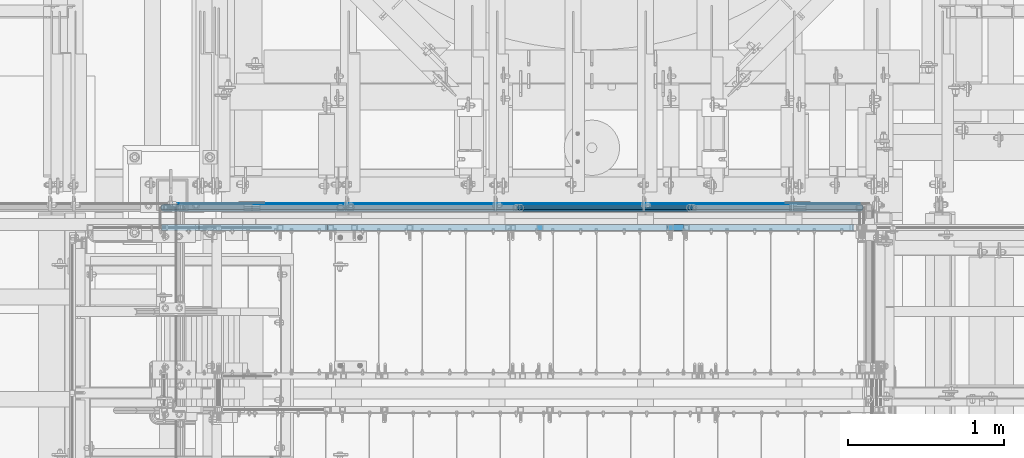
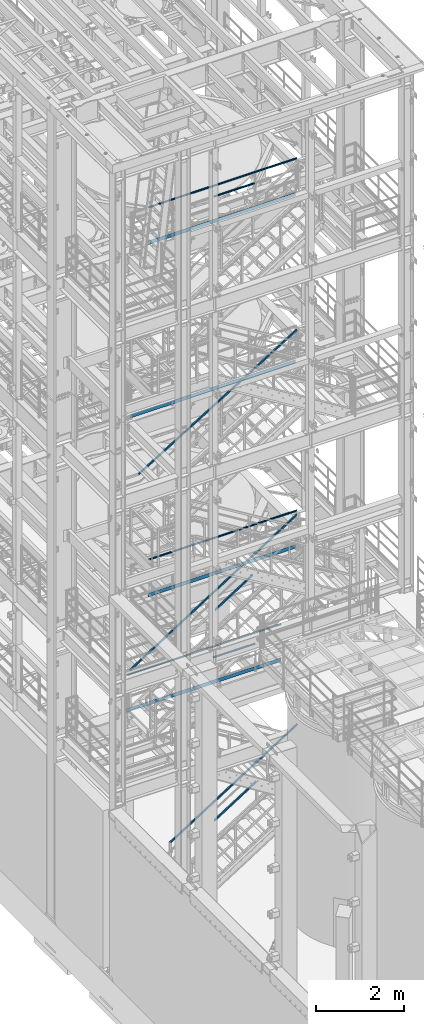
# One storey, part 978 of 1876: 9 beams, 5 members, 7 elements without a shape of their own.
"""IFC2X3 building model written with IfcOpenShell, lengths in millimetres."""

from ifc_helpers import new_model, si_unit, frame, origin_with_axes, place, context, subcontext, project, spatial, faceted_brep, material, type_object, element, aggregate, save


model = new_model("IFC2X3")

# Units and contexts
model_context = context("Model", 3, precision=1e-05, world=origin_with_axes())
body_context = subcontext(model_context, "Body", "Model", "MODEL_VIEW")
ifc_project = project(units=[si_unit("LENGTHUNIT", "METRE", prefix="MILLI"), si_unit("AREAUNIT", "SQUARE_METRE"), si_unit("VOLUMEUNIT", "CUBIC_METRE"), si_unit("MASSUNIT", "GRAM", prefix="KILO"), si_unit("TIMEUNIT", "SECOND"), si_unit("PLANEANGLEUNIT", "RADIAN"), si_unit("SOLIDANGLEUNIT", "STERADIAN"), si_unit("THERMODYNAMICTEMPERATUREUNIT", "DEGREE_CELSIUS"), si_unit("LUMINOUSINTENSITYUNIT", "LUMEN")], contexts=[model_context])

# Site, building, storey
site_placement = place(None, origin_with_axes())
site = spatial("IfcSite", under=ifc_project, at=site_placement, CompositionType="ELEMENT")
building_placement = place(site_placement, origin_with_axes())
building = spatial("IfcBuilding", under=site, at=building_placement, Name="Undefined", CompositionType="ELEMENT")
storey_placement = place(building_placement, origin_with_axes())
storey = spatial("IfcBuildingStorey", under=building, at=storey_placement, Name="Undefined", CompositionType="ELEMENT", Elevation=0.0)

# Assembly, beam
assembly_1_placement = place(storey_placement, origin_with_axes())
assembly_1 = element("IfcElementAssembly", 1, at=assembly_1_placement, inside=storey, Name="RAIL", AssemblyPlace="NOTDEFINED", PredefinedType="RIGID_FRAME")
ifc_material_1 = material()
beam_type_1 = type_object("IfcBeamType", Name="PIPE1-1/2SCH40", PredefinedType="NOTDEFINED")
beam_1_placement = place(assembly_1_placement, frame((2238.37499998822, -4654.55000114555, 9229.725), z_axis=(0.0, 0.0, -1.0), x_axis=(1.0, 0.0, 0.0)))
beam_1 = element("IfcBeam", 2, at=beam_1_placement, type_object=beam_type_1, material=ifc_material_1, Name="RAIL", ObjectType="PIPE1-1/2SCH40", context=body_context, shape_type="Brep", body=[
    faceted_brep([(1.58700000000044, -20.4470000000001, 0.0), (1.58700000000044, -17.7076214311801, 10.2235000000001), (3888.67649996469, -17.7076214311801, 10.2235000000001), (3898.89999996469, -20.4470000000001, 0.0), (1.58700000000044, -10.2235000000001, 17.7076214311801), (3881.19237853351, -10.2235000000001, 17.7076214311801), (1.58700000000044, 0.0, 20.4470000000001), (3878.45299996469, 0.0, 20.4470000000001), (1.58700000000044, 10.2235000000001, 17.7076214311801), (3881.19237853351, 10.2235000000001, 17.7076214311801), (1.58700000000044, 17.7076214311801, 10.2235000000001), (3888.67649996469, 17.7076214311801, 10.2235000000001), (1.58700000000044, 20.4470000000001, 0.0), (3898.89999996469, 20.4470000000001, 0.0), (1.58700000000044, 17.7076214311801, -10.2235000000001), (3909.12349996469, 17.7076214311801, -10.2235000000001), (1.58700000000044, 10.2235000000001, -17.7076214311801), (3916.60762139587, 10.2235000000001, -17.7076214311801), (1.58700000000044, 0.0, -20.4470000000001), (3919.34699996469, 0.0, -20.4470000000001), (1.58700000000044, -10.2235000000001, -17.7076214311801), (3916.60762139587, -10.2235000000001, -17.7076214311801), (1.58700000000044, -17.7076214311801, -10.2235000000001), (3909.12349996469, -17.7076214311801, -10.2235000000001), (1.58700000000044, -24.1300000000001, 0.0), (1.58700000000044, -20.8971929933186, -12.0649999999996), (3910.96499996469, -20.8971929933186, -12.0650000000005), (3898.89999996469, -24.1300000000001, 0.0), (1.58700000000044, -12.0649999999996, -20.8971929933186), (3919.79719295801, -12.0649999999996, -20.8971929933177), (1.58700000000044, 0.0, -24.1300000000001), (3923.02999996469, 0.0, -24.1299999999992), (1.58700000000044, 12.0649999999996, -20.8971929933186), (3919.79719295801, 12.0649999999996, -20.8971929933177), (1.58700000000044, 20.8971929933186, -12.0649999999996), (3910.96499996469, 20.8971929933186, -12.0650000000005), (1.58700000000044, 24.1300000000001, 0.0), (3898.89999996469, 24.1300000000001, 0.0), (1.58700000000044, 20.8971929933186, 12.0649999999996), (3886.83499996469, 20.8971929933186, 12.0650000000005), (1.58700000000044, 12.0649999999996, 20.8971929933186), (3878.00280697137, 12.0649999999996, 20.8971929933177), (1.58700000000044, 0.0, 24.1300000000001), (3874.76999996469, 0.0, 24.1299999999992), (1.58700000000044, -12.0649999999996, 20.8971929933186), (3878.00280697137, -12.0649999999996, 20.8971929933177), (1.58700000000044, -20.8971929933186, 12.0649999999996), (3886.83499996469, -20.8971929933186, 12.0650000000005)], [[[0, 1, 2, 3]], [[1, 4, 5, 2]], [[4, 6, 7, 5]], [[6, 8, 9, 7]], [[8, 10, 11, 9]], [[10, 12, 13, 11]], [[12, 14, 15, 13]], [[14, 16, 17, 15]], [[16, 18, 19, 17]], [[18, 20, 21, 19]], [[20, 22, 23, 21]], [[22, 0, 3, 23]], [[24, 25, 26, 27]], [[25, 28, 29, 26]], [[28, 30, 31, 29]], [[30, 32, 33, 31]], [[32, 34, 35, 33]], [[34, 36, 37, 35]], [[36, 38, 39, 37]], [[38, 40, 41, 39]], [[40, 42, 43, 41]], [[42, 44, 45, 43]], [[44, 46, 47, 45]], [[46, 24, 27, 47]], [[29, 31, 33, 35, 37, 39, 41, 43, 45, 47, 27, 26], [5, 7, 9, 11, 13, 15, 17, 19, 21, 23, 3, 2]], [[46, 44, 42, 40, 38, 36, 34, 32, 30, 28, 25, 24], [22, 20, 18, 16, 14, 12, 10, 8, 6, 4, 1, 0]]]),
])

# Assembly, beams
assembly_2_placement = place(storey_placement, origin_with_axes())
assembly_2 = element("IfcElementAssembly", 3, at=assembly_2_placement, inside=storey, Name="RAIL", AssemblyPlace="NOTDEFINED", PredefinedType="RIGID_FRAME")
beam_2_placement = place(assembly_2_placement, frame((3959.22499997644, -4654.55000114554, 18754.725), z_axis=(0.0, 0.0, -1.0), x_axis=(1.0, 0.0, 0.0)))
beam_2 = element("IfcBeam", 4, at=beam_2_placement, type_object=beam_type_1, material=ifc_material_1, Name="RAIL", ObjectType="PIPE1-1/2SCH40", context=body_context, shape_type="Brep", body=[
    faceted_brep([(0.0, 24.1299999999992, 0.0), (12.0650000000064, 20.8971929933177, -12.0649999999987), (12.0650000000064, 20.8971929933177, 12.0649999999987), (12.0650000000064, -20.8971929933177, 12.0649999999987), (12.0650000000064, -20.8971929933177, -12.0649999999987), (0.0, -24.1299999999992, 0.0), (20.8971929933249, -12.0650000000005, 20.8971929933177), (20.8971929933249, -12.0650000000005, 15.8661214311796), (15.2545715621445, -17.7076214311801, 10.2235000000001), (12.5151929933249, -20.4470000000001, 0.0), (15.2545715621445, -17.7076214311801, -10.2235000000001), (20.8971929933249, -12.0650000000005, -15.8661214311796), (20.8971929933249, -12.0650000000005, -20.8971929933177), (24.1300000000063, 0.0, -20.4470000000001), (24.1300000000063, 0.0, -24.130000000001), (21.3906214311868, -10.2235000000001, -17.7076214311819), (21.3906214311868, 10.2235000000001, -17.7076214311819), (20.8971929933249, 12.0650000000005, -15.8661214311796), (20.8971929933249, 12.0650000000005, -20.8971929933177), (15.2545715621445, 17.7076214311801, -10.2235000000001), (12.5151929933249, 20.4470000000001, 0.0), (15.2545715621445, 17.7076214311801, 10.2235000000001), (20.8971929933249, 12.0650000000005, 15.8661214311796), (20.8971929933249, 12.0650000000005, 20.8971929933177), (21.3906214311868, 10.2235000000001, 17.7076214311819), (24.1300000000064, 0.0, 20.4470000000001), (24.1300000000064, 0.0, 24.130000000001), (21.3906214311868, -10.2235000000001, 17.7076214311819), (1089.02499998822, 24.1300000000001, 0.0), (1076.95999998821, 20.8971929933186, -12.0650000000005), (1068.12780699489, 12.0649999999996, -20.8971929933177), (1089.02499998821, -24.1299999999865, 0.0), (1076.95999998821, -20.8971929933186, -12.0650000000005), (1076.95999998821, -20.8971929933186, 12.0650000000005), (1068.12780699489, -12.0649999999996, 20.8971929933177), (1068.12780699489, -12.0649999999996, -20.8971929933177), (1064.89499998821, 0.0, -24.1299999999992), (1067.63437855703, 10.2235000000001, -17.7076214311801), (1064.89499998821, 0.0, -20.4470000000001), (1068.12780699489, 12.0650000000132, -15.8661214311669), (1068.12780699489, -12.064999999986, -15.8661214311942), (1067.63437855703, -10.2235000000001, -17.7076214311801), (1073.77042842609, -17.7076214311801, -10.2235000000001), (1076.50980699491, -20.4470000000001, 0.0), (1073.77042842609, -17.7076214311801, 10.2235000000001), (1068.12780699489, -12.064999999986, 15.8661214311942), (1067.63437855703, -10.2235000000001, 17.7076214311801), (1064.89499998821, 0.0, 20.4470000000001), (1064.89499998821, 0.0, 24.1299999999992), (1068.12780699489, 12.0649999999996, 20.8971929933177), (1076.95999998821, 20.8971929933186, 12.0650000000005), (1068.12780699489, 12.0650000000132, 15.8661214311669), (1073.77042842606, 17.7076214311801, 10.2235000000001), (1076.50980699488, 20.4470000000001, 0.0), (1073.77042842606, 17.7076214311801, -10.2235000000001), (1067.63437855703, 10.2235000000001, 17.7076214311801)], [[[0, 1, 2]], [[3, 4, 5]], [[6, 7, 8, 9, 10, 11, 12, 4, 3]], [[13, 14, 12, 11, 15]], [[16, 17, 18, 14, 13]], [[2, 1, 18, 17, 19, 20, 21, 22, 23]], [[23, 22, 24, 25, 26]], [[26, 25, 27, 7, 6]], [[1, 0, 28, 29]], [[18, 1, 29, 30]], [[31, 32, 33]], [[6, 3, 33, 34]], [[3, 5, 31, 33]], [[5, 4, 32, 31]], [[4, 12, 35, 32]], [[12, 14, 36, 35]], [[14, 18, 30, 36]], [[37, 38, 36, 30, 39]], [[40, 35, 36, 38, 41]], [[33, 32, 35, 40, 42, 43, 44, 45, 34]], [[34, 45, 46, 47, 48]], [[26, 6, 34, 48]], [[2, 23, 49, 50]], [[23, 26, 48, 49]], [[0, 2, 50, 28]], [[28, 50, 29]], [[49, 51, 52, 53, 54, 39, 30, 29, 50]], [[48, 47, 55, 51, 49]], [[25, 24, 55, 47]], [[55, 24, 22, 21, 52, 51]], [[21, 20, 53, 52]], [[20, 19, 54, 53]], [[19, 17, 16, 37, 39, 54]], [[16, 13, 38, 37]], [[13, 15, 41, 38]], [[41, 15, 11, 10, 42, 40]], [[10, 9, 43, 42]], [[9, 8, 44, 43]], [[8, 7, 27, 46, 45, 44]], [[27, 25, 47, 46]]]),
])
beam_3_placement = place(assembly_2_placement, frame((2238.37499998822, -4654.55000114555, 19059.525), z_axis=(0.0, 0.0, -1.0), x_axis=(1.0, 0.0, 0.0)))
beam_3 = element("IfcBeam", 5, at=beam_3_placement, type_object=beam_type_1, material=ifc_material_1, Name="RAIL", ObjectType="PIPE1-1/2SCH40", context=body_context, shape_type="Brep", body=[
    faceted_brep([(1.58700000000044, -20.4470000000001, 0.0), (1.58700000000044, -17.7076214311801, 10.2235000000001), (3888.67649996469, -17.7076214311801, 10.2235000000001), (3898.89999996469, -20.4470000000001, 0.0), (1.58700000000044, -10.2235000000001, 17.7076214311801), (3881.19237853351, -10.2235000000001, 17.7076214311801), (1.58700000000044, 0.0, 20.4470000000001), (3878.45299996469, 0.0, 20.4470000000001), (1.58700000000044, 10.2235000000001, 17.7076214311801), (3881.19237853351, 10.2235000000001, 17.7076214311801), (1.58700000000044, 17.7076214311801, 10.2235000000001), (3888.67649996469, 17.7076214311801, 10.2235000000001), (1.58700000000044, 20.4470000000001, 0.0), (3898.89999996469, 20.4470000000001, 0.0), (1.58700000000044, 17.7076214311801, -10.2235000000001), (3909.12349996469, 17.7076214311801, -10.2235000000001), (1.58700000000044, 10.2235000000001, -17.7076214311801), (3916.60762139587, 10.2235000000001, -17.7076214311801), (1.58700000000044, 0.0, -20.4470000000001), (3919.34699996469, 0.0, -20.4470000000001), (1.58700000000044, -10.2235000000001, -17.7076214311801), (3916.60762139587, -10.2235000000001, -17.7076214311801), (1.58700000000044, -17.7076214311801, -10.2235000000001), (3909.12349996469, -17.7076214311801, -10.2235000000001), (1.58700000000044, -24.1300000000001, 0.0), (1.58700000000044, -20.8971929933186, -12.0649999999996), (3910.96499996469, -20.8971929933186, -12.0650000000005), (3898.89999996469, -24.1300000000001, 0.0), (1.58700000000044, -12.0649999999996, -20.8971929933186), (3919.79719295801, -12.0649999999996, -20.8971929933177), (1.58700000000044, 0.0, -24.1300000000001), (3923.02999996469, 0.0, -24.1299999999992), (1.58700000000044, 12.0649999999996, -20.8971929933186), (3919.79719295801, 12.0649999999996, -20.8971929933177), (1.58700000000044, 20.8971929933186, -12.0649999999996), (3910.96499996469, 20.8971929933186, -12.0650000000005), (1.58700000000044, 24.1300000000001, 0.0), (3898.89999996469, 24.1300000000001, 0.0), (1.58700000000044, 20.8971929933186, 12.0649999999996), (3886.83499996469, 20.8971929933186, 12.0650000000005), (1.58700000000044, 12.0649999999996, 20.8971929933186), (3878.00280697137, 12.0649999999996, 20.8971929933177), (1.58700000000044, 0.0, 24.1300000000001), (3874.76999996469, 0.0, 24.1299999999992), (1.58700000000044, -12.0649999999996, 20.8971929933186), (3878.00280697137, -12.0649999999996, 20.8971929933177), (1.58700000000044, -20.8971929933186, 12.0649999999996), (3886.83499996469, -20.8971929933186, 12.0650000000005)], [[[0, 1, 2, 3]], [[1, 4, 5, 2]], [[4, 6, 7, 5]], [[6, 8, 9, 7]], [[8, 10, 11, 9]], [[10, 12, 13, 11]], [[12, 14, 15, 13]], [[14, 16, 17, 15]], [[16, 18, 19, 17]], [[18, 20, 21, 19]], [[20, 22, 23, 21]], [[22, 0, 3, 23]], [[24, 25, 26, 27]], [[25, 28, 29, 26]], [[28, 30, 31, 29]], [[30, 32, 33, 31]], [[32, 34, 35, 33]], [[34, 36, 37, 35]], [[36, 38, 39, 37]], [[38, 40, 41, 39]], [[40, 42, 43, 41]], [[42, 44, 45, 43]], [[44, 46, 47, 45]], [[46, 24, 27, 47]], [[29, 31, 33, 35, 37, 39, 41, 43, 45, 47, 27, 26], [5, 7, 9, 11, 13, 15, 17, 19, 21, 23, 3, 2]], [[46, 44, 42, 40, 38, 36, 34, 32, 30, 28, 25, 24], [22, 20, 18, 16, 14, 12, 10, 8, 6, 4, 1, 0]]]),
])

assembly_3_placement = place(storey_placement, origin_with_axes())
assembly_3 = element("IfcElementAssembly", 6, at=assembly_3_placement, inside=storey, Name="RAIL", AssemblyPlace="NOTDEFINED", PredefinedType="RIGID_FRAME")
beam_4_placement = place(assembly_3_placement, frame((5067.30000007784, -4654.55000114548, 5902.325), z_axis=(0.0, 0.0, -1.0), x_axis=(-1.0, 0.0, 0.0)))
beam_4 = element("IfcBeam", 7, at=beam_4_placement, type_object=beam_type_1, material=ifc_material_1, Name="RAIL", ObjectType="PIPE1-1/2SCH40", context=body_context, shape_type="Brep", body=[
    faceted_brep([(0.0, 24.1299999999992, 0.0), (12.0650000000064, 20.8971929933177, -12.0649999999987), (12.0650000000064, 20.8971929933177, 12.0649999999987), (12.0650000000064, -20.8971929933177, 12.0649999999987), (12.0650000000064, -20.8971929933177, -12.0649999999987), (0.0, -24.1299999999992, 0.0), (20.8971929933249, -12.0650000000005, 20.8971929933177), (20.8971929933249, -12.0650000000005, 15.8661214311796), (15.2545715621445, -17.7076214311801, 10.2235000000001), (12.5151929933249, -20.4470000000001, 0.0), (15.2545715621445, -17.7076214311801, -10.2235000000001), (20.8971929933249, -12.0650000000005, -15.8661214311796), (20.8971929933249, -12.0650000000005, -20.8971929933177), (24.1300000000063, 0.0, -20.4470000000001), (24.1300000000063, 0.0, -24.130000000001), (21.3906214311868, -10.2235000000001, -17.7076214311819), (21.3906214311868, 10.2235000000001, -17.7076214311819), (20.8971929933249, 12.0650000000005, -15.8661214311796), (20.8971929933249, 12.0650000000005, -20.8971929933177), (15.2545715621445, 17.7076214311801, -10.2235000000001), (12.5151929933249, 20.4470000000001, 0.0), (15.2545715621445, 17.7076214311801, 10.2235000000001), (20.8971929933249, 12.0650000000005, 15.8661214311796), (20.8971929933249, 12.0650000000005, 20.8971929933177), (21.3906214311868, 10.2235000000001, 17.7076214311819), (24.1300000000064, 0.0, 20.4470000000001), (24.1300000000064, 0.0, 24.130000000001), (21.3906214311868, -10.2235000000001, 17.7076214311819), (1130.29999992215, 24.1300000000001, 0.0), (1118.23499992216, 20.8971929933186, -12.0649999999996), (1109.40280692884, 12.0649999999996, -20.8971929933186), (1130.29999992216, -24.1300000000274, 0.0), (1118.23499992216, -20.8971929933186, -12.0649999999996), (1118.23499992216, -20.8971929933186, 12.0649999999996), (1109.40280692884, -12.0649999999996, 20.8971929933186), (1109.40280692884, -12.0649999999996, -20.8971929933186), (1106.16999992216, 0.0, -24.1300000000001), (1108.90937849099, 10.2235000000001, -17.7076214311801), (1106.16999992216, 0.0, -20.4470000000001), (1109.40280692884, 12.0649999999723, -15.8661214312078), (1109.40280692884, -12.0650000000269, -15.8661214311533), (1108.90937849097, -10.2235000000001, -17.7076214311801), (1115.04542835999, -17.7076214311801, -10.2235000000001), (1117.78480692881, -20.4470000000001, 0.0), (1115.04542835999, -17.7076214311801, 10.2235000000001), (1109.40280692884, -12.0650000000269, 15.8661214311533), (1108.90937849097, -10.2235000000001, 17.7076214311801), (1106.16999992216, -9.09494701772928e-13, 20.4470000000001), (1106.16999992216, -9.09494701772928e-13, 24.1300000000001), (1109.40280692884, 12.0649999999996, 20.8971929933186), (1118.23499992216, 20.8971929933186, 12.0649999999996), (1109.40280692884, 12.0649999999723, 15.8661214312078), (1115.04542836005, 17.7076214311801, 10.2235000000001), (1117.78480692887, 20.4470000000001, 0.0), (1115.04542836005, 17.7076214311801, -10.2235000000001), (1108.90937849099, 10.2235000000001, 17.7076214311801)], [[[0, 1, 2]], [[3, 4, 5]], [[6, 7, 8, 9, 10, 11, 12, 4, 3]], [[13, 14, 12, 11, 15]], [[16, 17, 18, 14, 13]], [[2, 1, 18, 17, 19, 20, 21, 22, 23]], [[23, 22, 24, 25, 26]], [[26, 25, 27, 7, 6]], [[1, 0, 28, 29]], [[18, 1, 29, 30]], [[31, 32, 33]], [[6, 3, 33, 34]], [[3, 5, 31, 33]], [[5, 4, 32, 31]], [[4, 12, 35, 32]], [[12, 14, 36, 35]], [[14, 18, 30, 36]], [[37, 38, 36, 30, 39]], [[40, 35, 36, 38, 41]], [[33, 32, 35, 40, 42, 43, 44, 45, 34]], [[34, 45, 46, 47, 48]], [[26, 6, 34, 48]], [[2, 23, 49, 50]], [[23, 26, 48, 49]], [[0, 2, 50, 28]], [[28, 50, 29]], [[49, 51, 52, 53, 54, 39, 30, 29, 50]], [[48, 47, 55, 51, 49]], [[25, 24, 55, 47]], [[55, 24, 22, 21, 52, 51]], [[21, 20, 53, 52]], [[20, 19, 54, 53]], [[19, 17, 16, 37, 39, 54]], [[16, 13, 38, 37]], [[13, 15, 41, 38]], [[41, 15, 11, 10, 42, 40]], [[10, 9, 43, 42]], [[9, 8, 44, 43]], [[8, 7, 27, 46, 45, 44]], [[27, 25, 47, 46]]]),
])
beam_5_placement = place(assembly_3_placement, frame((5740.40000007785, -4654.55000114548, 6207.12500000001), z_axis=(0.0, 0.0, -1.0), x_axis=(-1.0, 0.0, 0.0)))
beam_5 = element("IfcBeam", 8, at=beam_5_placement, type_object=beam_type_1, material=ifc_material_1, Name="RAIL", ObjectType="PIPE1-1/2SCH40", context=body_context, shape_type="Brep", body=[
    faceted_brep([(1.58700000000044, -20.4470000000001, 0.0), (1.58700000000044, -17.7076214311801, 10.2235000000001), (4053.77649976647, -17.7076214311801, 10.2235000000001), (4063.99999976647, -20.4470000000001, 0.0), (1.58700000000044, -10.2235000000001, 17.7076214311801), (4046.29237833529, -10.2235000000001, 17.7076214311801), (1.58700000000044, 0.0, 20.4470000000001), (4043.55299976647, 0.0, 20.4470000000001), (1.58700000000044, 10.2235000000001, 17.7076214311801), (4046.29237833529, 10.2235000000001, 17.7076214311801), (1.58700000000044, 17.7076214311801, 10.2235000000001), (4053.77649976647, 17.7076214311801, 10.2235000000001), (1.58700000000044, 20.4470000000001, 0.0), (4063.99999976647, 20.4470000000001, 0.0), (1.58700000000044, 17.7076214311801, -10.2235000000001), (4074.22349976647, 17.7076214311801, -10.2235000000001), (1.58700000000044, 10.2235000000001, -17.7076214311801), (4081.70762119765, 10.2235000000001, -17.7076214311801), (1.58700000000044, 0.0, -20.4470000000001), (4084.44699976647, 0.0, -20.4470000000001), (1.58700000000044, -10.2235000000001, -17.7076214311801), (4081.70762119765, -10.2235000000001, -17.7076214311801), (1.58700000000044, -17.7076214311801, -10.2235000000001), (4074.22349976647, -17.7076214311801, -10.2235000000001), (1.58700000000044, -24.1300000000001, 0.0), (1.58700000000044, -20.8971929933186, -12.0649999999996), (4076.06499976647, -20.8971929933186, -12.0649999999996), (4063.99999976647, -24.1300000000001, 0.0), (1.58700000000044, -12.0649999999996, -20.8971929933186), (4084.89719275979, -12.0649999999996, -20.8971929933186), (1.58700000000044, 0.0, -24.1300000000001), (4088.12999976647, 0.0, -24.1300000000001), (1.58700000000044, 12.0649999999996, -20.8971929933186), (4084.89719275979, 12.0649999999996, -20.8971929933186), (1.58700000000044, 20.8971929933186, -12.0649999999996), (4076.06499976647, 20.8971929933186, -12.0649999999996), (1.58700000000044, 24.1300000000001, 0.0), (4063.99999976647, 24.1300000000001, 0.0), (1.58700000000044, 20.8971929933186, 12.0649999999996), (4051.93499976647, 20.8971929933186, 12.0649999999996), (1.58700000000044, 12.0649999999996, 20.8971929933186), (4043.10280677315, 12.0649999999996, 20.8971929933186), (1.58700000000044, 0.0, 24.1300000000001), (4039.86999976647, 0.0, 24.1300000000001), (1.58700000000044, -12.0649999999996, 20.8971929933186), (4043.10280677315, -12.0649999999996, 20.8971929933186), (1.58700000000044, -20.8971929933186, 12.0649999999996), (4051.93499976647, -20.8971929933186, 12.0649999999996)], [[[0, 1, 2, 3]], [[1, 4, 5, 2]], [[4, 6, 7, 5]], [[6, 8, 9, 7]], [[8, 10, 11, 9]], [[10, 12, 13, 11]], [[12, 14, 15, 13]], [[14, 16, 17, 15]], [[16, 18, 19, 17]], [[18, 20, 21, 19]], [[20, 22, 23, 21]], [[22, 0, 3, 23]], [[24, 25, 26, 27]], [[25, 28, 29, 26]], [[28, 30, 31, 29]], [[30, 32, 33, 31]], [[32, 34, 35, 33]], [[34, 36, 37, 35]], [[36, 38, 39, 37]], [[38, 40, 41, 39]], [[40, 42, 43, 41]], [[42, 44, 45, 43]], [[44, 46, 47, 45]], [[46, 24, 27, 47]], [[29, 31, 33, 35, 37, 39, 41, 43, 45, 47, 27, 26], [5, 7, 9, 11, 13, 15, 17, 19, 21, 23, 3, 2]], [[46, 44, 42, 40, 38, 36, 34, 32, 30, 28, 25, 24], [22, 20, 18, 16, 14, 12, 10, 8, 6, 4, 1, 0]]]),
])

# Beam
ifc_material_2 = material(Name="STEEL/A36")
beam_type_2 = type_object("IfcBeamType", PredefinedType="NOTDEFINED")
beam_6_placement = place(assembly_1_placement, frame((2238.37499998823, -4627.56250191054, 8220.075), z_axis=(0.0, 0.0, 1.0), x_axis=(1.0, 0.0, 0.0)))
beam_6 = element("IfcBeam", 9, at=beam_6_placement, type_object=beam_type_2, material=ifc_material_2, Name="PLATE", context=body_context, shape_type="Brep", body=[
    faceted_brep([(1.58750000000009, 3.17500000000018, -50.8000000000002), (1.58750000000009, 3.17500000000018, 50.7999999999993), (3898.89999996468, 3.17500000000018, 50.7999999999993), (3898.89999996468, 3.17500000000018, -50.8000000000002), (1.58750000000009, -3.17500000000018, 50.7999999999993), (3898.89999996468, -3.17500000000018, 50.7999999999993), (1.58750000000009, -3.17500000000018, -50.8000000000002), (3898.89999996468, -3.17500000000018, -50.8000000000002)], [[[0, 1, 2, 3]], [[1, 4, 5, 2]], [[4, 6, 7, 5]], [[6, 0, 3, 7]], [[5, 7, 3, 2]], [[6, 4, 1, 0]]]),
])

aggregate(assembly_1, [beam_1, beam_6])

beam_7_placement = place(assembly_2_placement, frame((2238.37499998823, -4627.56250191054, 18049.875), z_axis=(0.0, 0.0, 1.0), x_axis=(1.0, 0.0, 0.0)))
beam_7 = element("IfcBeam", 10, at=beam_7_placement, type_object=beam_type_2, material=ifc_material_2, Name="PLATE", context=body_context, shape_type="Brep", body=[
    faceted_brep([(1.58750000000009, 3.17500000000018, -50.8000000000002), (1.58750000000009, 3.17500000000018, 50.7999999999993), (3898.89999996468, 3.17500000000018, 50.7999999999993), (3898.89999996468, 3.17500000000018, -50.8000000000002), (1.58750000000009, -3.17500000000018, 50.7999999999993), (3898.89999996468, -3.17500000000018, 50.7999999999993), (1.58750000000009, -3.17500000000018, -50.8000000000002), (3898.89999996468, -3.17500000000018, -50.8000000000002)], [[[0, 1, 2, 3]], [[1, 4, 5, 2]], [[4, 6, 7, 5]], [[6, 0, 3, 7]], [[5, 7, 3, 2]], [[6, 4, 1, 0]]]),
])

aggregate(assembly_2, [beam_2, beam_3, beam_7])

# Assembly, beam
assembly_4_placement = place(storey_placement, origin_with_axes())
assembly_4 = element("IfcElementAssembly", 11, at=assembly_4_placement, inside=storey, Name="RAIL", AssemblyPlace="NOTDEFINED", PredefinedType="RIGID_FRAME")
beam_8_placement = place(assembly_4_placement, frame((1781.175, -4627.56250191054, 13376.275), z_axis=(0.0, 0.0, 1.0), x_axis=(1.0, 0.0, 0.0)))
beam_8 = element("IfcBeam", 12, at=beam_8_placement, type_object=beam_type_2, material=ifc_material_2, Name="PLATE", context=body_context, shape_type="Brep", body=[
    faceted_brep([(0.0, 3.17500000000018, -50.8000000000002), (0.0, 3.17500000000018, 50.8000000000002), (4356.09999995291, 3.17500000000018, 50.7999999999993), (4356.09999995291, 3.17500000000018, -50.7999999999993), (0.0, -3.17500000000018, 50.8000000000002), (4356.09999995291, -3.17500000000018, 50.7999999999993), (0.0, -3.17500000000018, -50.8000000000002), (4356.09999995291, -3.17500000000018, -50.7999999999993)], [[[0, 1, 2, 3]], [[1, 4, 5, 2]], [[4, 6, 7, 5]], [[6, 0, 3, 7]], [[5, 7, 3, 2]], [[6, 4, 1, 0]]]),
])
aggregate(assembly_4, [beam_8])

# Beam
beam_9_placement = place(assembly_3_placement, frame((1676.40000031137, -4627.56250114554, 5197.47500003018), z_axis=(0.0, 0.0, 1.0), x_axis=(1.0, 0.0, 0.0)))
beam_9 = element("IfcBeam", 13, at=beam_9_placement, type_object=beam_type_2, material=ifc_material_2, Name="PLATE", context=body_context, shape_type="Brep", body=[
    faceted_brep([(0.0, 3.17500000000018, -50.8000000000002), (0.0, 3.17500000000018, 50.8000000000002), (4062.41249976729, 3.17500000000018, 50.8000000000002), (4062.41249976729, 3.17500000000018, -50.8000000000002), (0.0, -3.17500000000018, 50.8000000000002), (4062.41249976729, -3.17500000000018, 50.8000000000002), (0.0, -3.17500000000018, -50.8000000000002), (4062.41249976729, -3.17500000000018, -50.8000000000002)], [[[0, 1, 2, 3]], [[1, 4, 5, 2]], [[4, 6, 7, 5]], [[6, 0, 3, 7]], [[5, 7, 3, 2]], [[6, 4, 1, 0]]]),
])

aggregate(assembly_3, [beam_9, beam_4, beam_5])

# Assembly, members
assembly_5_placement = place(storey_placement, origin_with_axes())
assembly_5 = element("IfcElementAssembly", 14, at=assembly_5_placement, inside=storey, Name="RAIL", AssemblyPlace="NOTDEFINED", PredefinedType="RIGID_FRAME")
ifc_material_3 = material()
member_type = type_object("IfcMemberType", Name="HSS1-1/2X1-1/2X1/8", PredefinedType="NOTDEFINED")
member_1_placement = place(assembly_5_placement, frame((3911.59999717476, -4781.55000114554, 7306.25226969377), z_axis=(-0.536875491934336, 0.0, 0.843661487896813), x_axis=(0.843661487896813, 0.0, 0.536875491934336)))
member_1 = element("IfcMember", 15, at=member_1_placement, type_object=member_type, material=ifc_material_3, Name="RAIL", ObjectType="HSS1-1/2X1-1/2X1/8", context=body_context, shape_type="Brep", body=[
    faceted_brep([(10.4574188235219, -19.0499992349996, -19.0499992349946), (34.7028723789208, -19.0499992349996, 19.0499992350083), (34.7028723789208, 19.0499992349996, 19.0499992350083), (10.4574188235219, 19.0499992349996, -19.0499992349946), (32.6824178653787, 15.8749992829999, 15.8749992830085), (32.6824178653787, -15.8749992829999, 15.8749992830085), (12.4778733370622, -15.8749992829999, -15.8749992829939), (12.4778733370622, 15.8749992829999, -15.8749992829939), (1169.57160433941, 19.0499992349996, -19.04999923487), (1169.57160433941, -19.0499992349996, -19.04999923487), (1193.81705789482, -19.0499992349996, 19.0499992351256), (1193.81705789482, 19.0499992349996, 19.0499992351256), (1191.79660338128, -15.8749992829999, 15.8749992831263), (1191.79660338128, 15.8749992829999, 15.8749992831263), (1171.59205885295, 15.8749992829999, -15.8749992828712), (1171.59205885295, -15.8749992829999, -15.8749992828712)], [[[0, 1, 2, 3], [4, 5, 6, 7]], [[8, 9, 0, 3]], [[9, 10, 1, 0]], [[10, 11, 2, 1]], [[11, 8, 3, 2]], [[10, 9, 8, 11], [12, 13, 14, 15]], [[13, 12, 5, 4]], [[14, 13, 4, 7]], [[15, 14, 7, 6]], [[12, 15, 6, 5]]]),
])
member_2_placement = place(assembly_5_placement, frame((6081.03214427849, -4781.55000191054, 9220.19999873693), z_axis=(0.536875491934335, 0.0, -0.843661487896814), x_axis=(-0.843661487896813, 0.0, -0.536875491934336)))
member_2 = element("IfcMember", 16, at=member_2_placement, type_object=member_type, material=ifc_material_3, Name="RAIL", ObjectType="HSS1-1/2X1-1/2X1/8", context=body_context, shape_type="Brep", body=[
    faceted_brep([(-4.62281069927667, 15.8749992829999, -15.8749992829999), (-4.62281069927667, -15.8749992829999, -15.8749992829999), (5229.56696317395, -15.8749992829999, -15.8749992811681), (5229.56696317395, 15.8749992829999, -15.8749992811681), (4.62281070567769, -15.8749992829999, 15.8749992829999), (5212.13793187573, -15.8749992829999, 15.8749992848452), (4.62281070567769, 15.8749992829999, 15.8749992829999), (5212.13793187573, 15.8749992829999, 15.8749992848452), (-5.54737286755244, 19.0499992349996, -19.0499992349996), (5.54737287395346, 19.0499992349996, 19.0499992349996), (5210.39502869354, 19.0499992349996, 19.0499992368468), (5231.30986635614, 19.0499992349996, -19.0499992331688), (5.54737287395346, -19.0499992349996, 19.0499992349996), (5210.39502869354, -19.0499992349996, 19.0499992368468), (-5.54737286755244, -19.0499992349996, -19.0499992349996), (5231.30986635614, -19.0499992349996, -19.0499992331688)], [[[0, 1, 2, 3]], [[1, 4, 5, 2]], [[4, 6, 7, 5]], [[6, 0, 3, 7]], [[8, 9, 10, 11]], [[9, 12, 13, 10]], [[12, 14, 15, 13]], [[14, 8, 11, 15]], [[13, 15, 11, 10], [5, 7, 3, 2]], [[14, 12, 9, 8], [6, 4, 1, 0]]]),
])
aggregate(assembly_5, [member_1, member_2])

assembly_6_placement = place(storey_placement, origin_with_axes())
assembly_6 = element("IfcElementAssembly", 17, at=assembly_6_placement, inside=storey, Name="RAIL", AssemblyPlace="NOTDEFINED", PredefinedType="RIGID_FRAME")
member_3_placement = place(assembly_6_placement, frame((3884.21562501411, -4781.55000114554, 1434.51790605298), z_axis=(-0.53569741975471, 0.0, 0.844410015613355), x_axis=(0.844410015326383, 0.0, 0.535697420207059)))
member_3 = element("IfcMember", 18, at=member_3_placement, type_object=member_type, material=ifc_material_3, Name="RAIL", ObjectType="HSS1-1/2X1-1/2X1/8", context=body_context, shape_type="Brep", body=[
    faceted_brep([(10.4747262991696, -19.0499992349996, -19.0499992349991), (34.6455325374254, -19.0499992349996, 19.049999235012), (34.6455325374254, 19.0499992349996, 19.049999235012), (10.4747262991696, 19.0499992349996, -19.0499992349991), (32.6312986338025, 15.8749992829999, 15.8749992830109), (32.6312986338025, -15.8749992829999, 15.8749992830109), (12.4889602027924, -15.8749992829999, -15.8749992829981), (12.4889602027924, 15.8749992829999, -15.8749992829981), (1316.61227338722, 19.0499992349996, -19.0499992349723), (1316.61227338722, -19.0499992349996, -19.0499992349723), (1340.78307962549, -19.0499992349996, 19.0499992350333), (1340.78307962549, 19.0499992349996, 19.0499992350333), (1338.76884572186, -15.8749992829999, 15.8749992830328), (1338.76884572186, 15.8749992829999, 15.8749992830328), (1318.62650729085, 15.8749992829999, -15.8749992829719), (1318.62650729085, -15.8749992829999, -15.8749992829719)], [[[0, 1, 2, 3], [4, 5, 6, 7]], [[8, 9, 0, 3]], [[9, 10, 1, 0]], [[10, 11, 2, 1]], [[11, 8, 3, 2]], [[10, 9, 8, 11], [12, 13, 14, 15]], [[13, 12, 5, 4]], [[14, 13, 4, 7]], [[15, 14, 7, 6]], [[12, 15, 6, 5]]]),
])
member_4_placement = place(assembly_6_placement, frame((6096.0000003818, -4781.55000114554, 3371.08362061158), z_axis=(0.535697419754711, 0.0, -0.844410015613354), x_axis=(-0.844410015613354, 0.0, -0.53569741975471)))
member_4 = element("IfcMember", 19, at=member_4_placement, type_object=member_type, material=ifc_material_3, Name="RAIL", ObjectType="HSS1-1/2X1-1/2X1/8", context=body_context, shape_type="Brep", body=[
    faceted_brep([(-4.61079482035893, 15.8749992829999, -15.8749992830034), (-4.61079482035893, -15.8749992829999, -15.8749992830034), (3979.31187617968, -15.8749992829999, -15.8749992819418), (3979.31187617968, 15.8749992829999, -15.8749992819418), (4.61079481841625, -15.8749992829999, 15.8749992830026), (3961.85399909883, -15.8749992829999, 15.8749992840581), (4.61079481841625, 15.8749992829999, 15.8749992830026), (3961.85399909883, 15.8749992829999, 15.8749992840581), (-5.53295381194494, 19.0499992349996, -19.0499992350046), (5.53295381000225, 19.0499992349996, 19.0499992350038), (3960.10821133829, 19.0499992349996, 19.0499992360577), (3981.05766394022, 19.0499992349996, -19.0499992339418), (5.53295381000225, -19.0499992349996, 19.0499992350038), (3960.10821133829, -19.0499992349996, 19.0499992360577), (-5.53295381194494, -19.0499992349996, -19.0499992350046), (3981.05766394022, -19.0499992349996, -19.0499992339418)], [[[0, 1, 2, 3]], [[1, 4, 5, 2]], [[4, 6, 7, 5]], [[6, 0, 3, 7]], [[8, 9, 10, 11]], [[9, 12, 13, 10]], [[12, 14, 15, 13]], [[14, 8, 11, 15]], [[13, 15, 11, 10], [5, 7, 3, 2]], [[14, 12, 9, 8], [6, 4, 1, 0]]]),
])
aggregate(assembly_6, [member_3, member_4])

# Assembly, member
assembly_7_placement = place(storey_placement, origin_with_axes())
assembly_7 = element("IfcElementAssembly", 20, at=assembly_7_placement, inside=storey, Name="RAIL", AssemblyPlace="NOTDEFINED", PredefinedType="RIGID_FRAME")
member_5_placement = place(assembly_7_placement, frame((6080.51600985087, -4781.55000191054, 14376.3999999999), z_axis=(0.523953411146183, 0.0, -0.851746924237639), x_axis=(-0.851746924237639, 0.0, -0.523953411146184)))
member_5 = element("IfcMember", 21, at=member_5_placement, type_object=member_type, material=ifc_material_3, Name="RAIL", ObjectType="HSS1-1/2X1-1/2X1/8", context=body_context, shape_type="Brep", body=[
    faceted_brep([(-4.49184492785935, 15.8749992829999, -15.8749992829999), (-4.49184492785935, -15.8749992829999, -15.8749992829999), (4897.80470740708, -15.8749992829999, -15.8749992841258), (4897.80470740708, 15.8749992829999, -15.8749992841258), (4.49184492431232, -15.8749992829999, 15.8749992829999), (4906.78839725977, -15.8749992829999, 15.8749992818775), (4.49184492431232, 15.8749992829999, 15.8749992829999), (4906.78839725977, 15.8749992829999, 15.8749992818775), (-5.39021394007068, 19.0499992349996, -19.0499992349996), (5.39021393652274, 19.0499992349996, 19.0499992349996), (4907.68676627204, 19.0499992349996, 19.0499992338773), (4896.90633839482, 19.0499992349996, -19.0499992361256), (5.39021393652274, -19.0499992349996, 19.0499992349996), (4907.68676627204, -19.0499992349996, 19.0499992338773), (-5.39021394007068, -19.0499992349996, -19.0499992349996), (4896.90633839482, -19.0499992349996, -19.0499992361256)], [[[0, 1, 2, 3]], [[1, 4, 5, 2]], [[4, 6, 7, 5]], [[6, 0, 3, 7]], [[8, 9, 10, 11]], [[9, 12, 13, 10]], [[12, 14, 15, 13]], [[14, 8, 11, 15]], [[13, 15, 11, 10], [5, 7, 3, 2]], [[14, 12, 9, 8], [6, 4, 1, 0]]]),
])
aggregate(assembly_7, [member_5])

save(model, "model.ifc")
